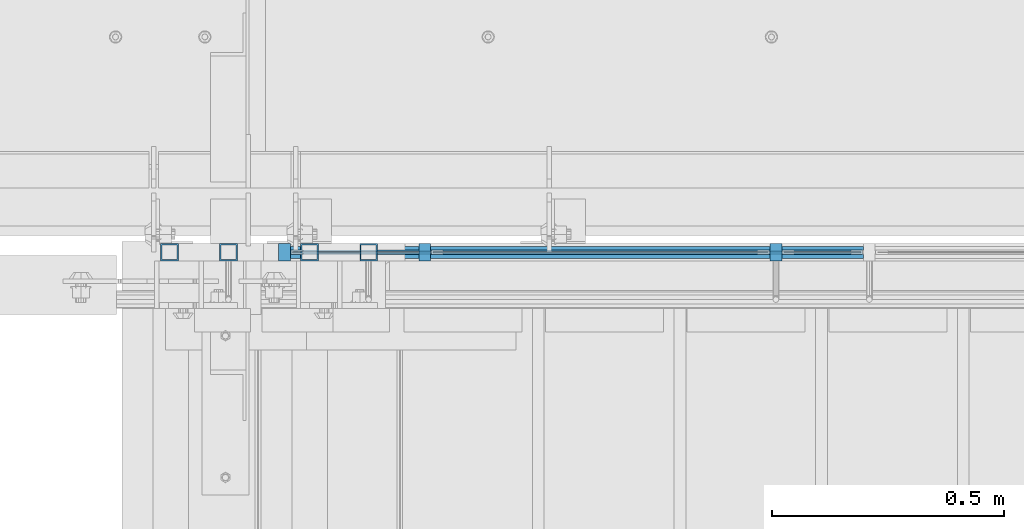
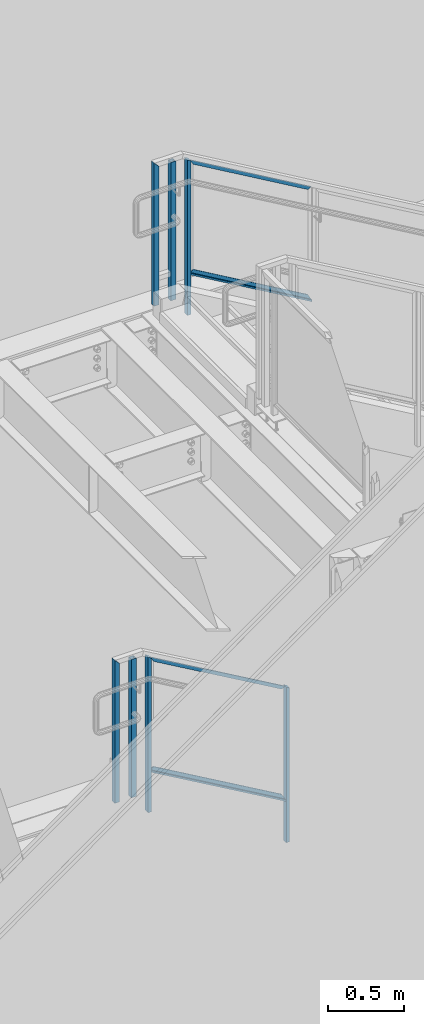
# One storey, part 792 of 1179: 9 members, 4 beams, 2 elements without a shape of their own.
"""IFC2X3 building model written with IfcOpenShell, lengths in millimetres."""

from ifc_helpers import new_model, si_unit, frame, origin_with_axes, place, context, subcontext, project, spatial, faceted_brep, material, type_object, element, aggregate, save


model = new_model("IFC2X3")

# Units and contexts
model_context = context("Model", 3, precision=1e-05, world=origin_with_axes())
body_context = subcontext(model_context, "Body", "Model", "MODEL_VIEW")
ifc_project = project(units=[si_unit("LENGTHUNIT", "METRE", prefix="MILLI"), si_unit("AREAUNIT", "SQUARE_METRE"), si_unit("VOLUMEUNIT", "CUBIC_METRE"), si_unit("MASSUNIT", "GRAM", prefix="KILO"), si_unit("TIMEUNIT", "SECOND"), si_unit("PLANEANGLEUNIT", "RADIAN"), si_unit("SOLIDANGLEUNIT", "STERADIAN"), si_unit("THERMODYNAMICTEMPERATUREUNIT", "DEGREE_CELSIUS"), si_unit("LUMINOUSINTENSITYUNIT", "LUMEN")], contexts=[model_context])

# Site, building, storey
site_placement = place(None, origin_with_axes())
site = spatial("IfcSite", under=ifc_project, at=site_placement, CompositionType="ELEMENT")
building_placement = place(site_placement, origin_with_axes())
building = spatial("IfcBuilding", under=site, at=building_placement, Name="Undefined", CompositionType="ELEMENT")
storey_placement = place(building_placement, origin_with_axes())
storey = spatial("IfcBuildingStorey", under=building, at=storey_placement, Name="Undefined", CompositionType="ELEMENT", Elevation=0.0)

# Assembly, member
assembly_1_placement = place(storey_placement, origin_with_axes())
assembly_1 = element("IfcElementAssembly", 1, at=assembly_1_placement, inside=storey, Name="GUARDRAIL", AssemblyPlace="NOTDEFINED", PredefinedType="RIGID_FRAME")
ifc_material_1 = material(Name="STEEL/A36")
member_type_1 = type_object("IfcMemberType", PredefinedType="NOTDEFINED")
member_1_placement = place(assembly_1_placement, frame((19853.2749999269, 41065.449999238, 7913.42903983498), z_axis=(0.0, -1.0, 0.0), x_axis=(0.0, 0.0, 1.0)))
member_1 = element("IfcMember", 2, at=member_1_placement, type_object=member_type_1, material=ifc_material_1, Name="POST", context=body_context, shape_type="Brep", body=[
    faceted_brep([(0.0, 12.7000000000007, -19.0500000000029), (0.0, 12.7000000000007, 19.0500000000029), (1257.9937907086, 12.7000000000007, 19.0500000000029), (1257.9937907086, 12.7000000000007, -19.0500000000029), (0.0, -12.7000000000007, 19.0500000000029), (1243.17712405909, -12.7000000000007, 19.0500000000029), (0.0, -12.7000000000007, -19.0500000000029), (1243.17712405909, -12.7000000000007, -19.0500000000029)], [[[0, 1, 2, 3]], [[1, 4, 5, 2]], [[4, 6, 7, 5]], [[6, 0, 3, 7]], [[5, 7, 3, 2]], [[6, 4, 1, 0]]]),
])

# Assembly, members
assembly_2_placement = place(storey_placement, origin_with_axes())
assembly_2 = element("IfcElementAssembly", 3, at=assembly_2_placement, inside=storey, Name="GUARDRAIL", AssemblyPlace="NOTDEFINED", PredefinedType="RIGID_FRAME")
member_2_placement = place(assembly_2_placement, frame((20608.9249611471, 41065.4499993604, 3388.43033674532), z_axis=(0.0, -1.0, 0.0), x_axis=(0.0, 0.0, 1.0)))
member_2 = element("IfcMember", 4, at=member_2_placement, type_object=member_type_1, material=ifc_material_1, Name="POST", context=body_context, shape_type="Brep", body=[
    faceted_brep([(0.0, 12.7000000000007, -19.0500000000029), (0.0, 12.7000000000007, 19.0500000000029), (1257.59245944594, 12.7000000000007, 19.0500000000029), (1257.59245944594, 12.7000000000007, -19.0500000000029), (0.0, -12.7000000000007, 19.0500000000029), (1242.88603583053, -12.7000000000007, 19.0500000000029), (0.0, -12.7000000000007, -19.0500000000029), (1242.88603583053, -12.7000000000007, -19.0500000000029)], [[[0, 1, 2, 3]], [[1, 4, 5, 2]], [[4, 6, 7, 5]], [[6, 0, 3, 7]], [[5, 7, 3, 2]], [[6, 4, 1, 0]]]),
])
member_3_placement = place(assembly_2_placement, frame((19551.6499976895, 41065.4499993638, 4000.58519857922), z_axis=(0.0, -1.0, 0.0), x_axis=(0.0, 0.0, 1.0)))
member_3 = element("IfcMember", 5, at=member_3_placement, type_object=member_type_1, material=ifc_material_1, Name="POST", context=body_context, shape_type="Brep", body=[
    faceted_brep([(1242.88603583053, -12.7000000000007, 19.0500000000029), (1242.88603583053, -12.7000000000007, -19.0500000000029), (1257.59245944594, 12.7000000000007, -19.0500000000029), (1257.59245944594, 12.7000000000007, 19.0500000000029), (0.0, -12.7000000000007, -19.0500000000029), (0.0, -12.7000000000007, 19.0500000000029), (0.0, 12.7000000000007, 19.0500000000029), (0.0, 12.7000000000007, -19.0500000000029)], [[[0, 1, 2, 3]], [[4, 5, 6, 7]], [[7, 6, 3, 2]], [[4, 7, 2, 1]], [[5, 4, 1, 0]], [[6, 5, 0, 3]]]),
])

# Beam
ifc_material_2 = material(Name="STEEL/BUY-OUT")
beam_type = type_object("IfcBeamType", PredefinedType="NOTDEFINED")
beam_1_placement = place(assembly_1_placement, frame((20294.9861896626, 41062.2751647691, 8025.17294760653), z_axis=(0.863778851027978, 0.0, -0.503871111016285), x_axis=(-0.503871111016286, 0.0, -0.863778851027978)))
beam_1 = element("IfcBeam", 6, at=beam_1_placement, type_object=beam_type, material=ifc_material_2, Name="U-EDGE", context=body_context, shape_type="Brep", body=[
    faceted_brep([(3.02679836750031e-09, 1.58750000000146, -465.424288071716), (3.02316038869321e-09, -1.58750000000146, -465.424288071717), (-3.58704710379243e-09, -1.58750000000146, 550.296660657488), (-3.58704710379243e-09, 1.58750000000146, 550.296660657488), (22.2250000928143, 1.58750000000146, -478.189679507572), (22.2250000632448, 1.58750000000146, 588.991208057043), (22.2250000826898, 4.76250001285371, -478.189679501758), (22.2250000757122, 4.76249998416461, 588.991208078747), (1.59241608344018e-07, 4.76250000984146, -465.424288161439), (1.58372131409124e-07, 4.76249998836283, 550.296660939461), (1.59241608344018e-07, 7.93750000983709, -465.424288161439), (1.58372131409124e-07, 7.93749998836574, 550.296660939461), (25.4000000827036, 7.93750001290027, -480.013306842378), (25.4000000343149, 7.9375, 594.519), (25.4000000928609, -1.58750000000146, -480.013306848216), (25.4000000343149, -1.58750000000146, 594.519)], [[[0, 1, 2, 3]], [[4, 0, 3, 5]], [[6, 4, 5, 7]], [[8, 6, 7, 9]], [[10, 8, 9, 11]], [[12, 10, 11, 13]], [[14, 12, 13, 15]], [[11, 9, 7, 5, 3, 2, 15, 13]], [[1, 14, 15, 2]], [[0, 4, 6, 8, 10, 12, 14, 1]]]),
])

beam_2_placement = place(assembly_1_placement, frame((20269.3895413051, 41062.2751647691, 8890.03748633002), z_axis=(0.863778851027978, 0.0, -0.503871111016285), x_axis=(0.503871025088838, 0.0, 0.863778901152328)))
beam_2 = element("IfcBeam", 7, at=beam_2_placement, type_object=beam_type, material=ifc_material_2, Name="U-EDGE", context=body_context, shape_type="Brep", body=[
    faceted_brep([(-1.33470166474581e-07, -4.76249999994616, -435.790965618296), (-1.33470166474581e-07, -7.93749999994907, -435.790965618296), (-1.34041329147294e-07, -7.93750000006548, 579.929993147438), (-1.34041329147294e-07, -4.76250000006257, 579.929993147438), (22.224999933358, -4.76249999989523, -474.486507128395), (22.2249999328378, -4.76250000012806, 592.695373883196), (22.2249999333071, -1.58750000000146, -474.486507128307), (22.2249999328997, -1.58750000000146, 592.695373883229), (2.25554686039686e-10, -1.58750000000146, -435.790965851076), (0.0, -1.58750000000146, 579.92999369853), (2.25554686039686e-10, 1.58750000000146, -435.790965851076), (0.0, 1.58750000000146, 579.92999369853), (25.39999993331, 1.58750000000146, -480.014441613133), (25.3999999489688, 1.58750000000146, 594.519), (25.399999933361, -7.93749999989086, -480.014441613221), (25.3999999489688, -7.9375, 594.519)], [[[0, 1, 2, 3]], [[4, 0, 3, 5]], [[6, 4, 5, 7]], [[8, 6, 7, 9]], [[10, 8, 9, 11]], [[12, 10, 11, 13]], [[14, 12, 13, 15]], [[11, 9, 7, 5, 3, 2, 15, 13]], [[1, 14, 15, 2]], [[0, 4, 6, 8, 10, 12, 14, 1]]]),
])

beam_3_placement = place(assembly_2_placement, frame((20092.8623203506, 41062.2751647691, 4055.74095164783), z_axis=(0.86540914081268, 0.0, -0.501065882891521), x_axis=(-0.501065882891527, 0.0, -0.865409140812677)))
beam_3 = element("IfcBeam", 8, at=beam_3_placement, type_object=beam_type, material=ifc_material_2, Name="U-EDGE", context=body_context, shape_type="Brep", body=[
    faceted_brep([(-2.17914930544794e-09, 1.58750000000146, -579.8750616161), (-2.17914930544794e-09, -1.58750000000146, -579.8750616161), (2.06819095183164e-09, -1.58750000000146, 550.462303003866), (2.06819095183164e-09, 1.58750000000146, 550.462303003866), (22.2250000220702, 1.58750000000146, -592.688577145202), (22.225000051898, 1.58750000000146, 589.01191290709), (22.225000034794, 4.76249998386629, -592.688577152541), (22.2250000392505, 4.7625000160333, 589.011912885151), (7.50696926843375e-08, 4.76249998754065, -579.875061660634), (7.28450686438009e-08, 4.7625000118278, 550.462303126626), (7.50696926843375e-08, 7.93749998753628, -579.875061660634), (7.28450686438009e-08, 7.93750001182343, 550.462303126626), (25.4000000347896, 7.93749998381099, -594.518999999977), (25.4000000343149, 7.9375, 594.519), (25.4000000220258, -1.58750000000146, -594.518999999807), (25.4000000343149, -1.58750000000146, 594.519)], [[[0, 1, 2, 3]], [[4, 0, 3, 5]], [[6, 4, 5, 7]], [[8, 6, 7, 9]], [[10, 8, 9, 11]], [[12, 10, 11, 13]], [[14, 12, 13, 15]], [[11, 9, 7, 5, 3, 2, 15, 13]], [[1, 14, 15, 2]], [[0, 4, 6, 8, 10, 12, 14, 1]]]),
])

beam_4_placement = place(assembly_2_placement, frame((20067.408210734, 41062.2751647691, 4921.4162257045), z_axis=(0.86540914081268, 0.0, -0.501065882891521), x_axis=(0.501065882891522, 0.0, 0.865409140812679)))
beam_4 = element("IfcBeam", 9, at=beam_4_placement, type_object=beam_type, material=ifc_material_2, Name="U-EDGE", context=body_context, shape_type="Brep", body=[
    faceted_brep([(-5.08043740410358e-09, -4.76250001176231, -550.462297073285), (-5.08043740410358e-09, -7.93750001176522, -550.462297073285), (2.06819095183164e-09, -7.93749998760177, 579.875144306196), (2.06819095183164e-09, -4.76249998760613, 579.875144306196), (22.2249999989635, -4.76250001590233, -589.011912123857), (22.2249999997566, -4.76249998399726, 592.68851804268), (22.2250000115582, -1.58750000000146, -589.011912145696), (22.2249999870892, -1.58750000000146, 592.68851803538), (-3.47426976077259e-10, -1.58750000000146, -550.462297081494), (3.69254848919809e-10, -1.58750000000146, 579.875144305217), (-3.47426976077259e-10, 1.58750000000146, -550.462297081494), (3.69254848919809e-10, 1.58750000000146, 579.875144305217), (25.4000001784334, 1.58750000000146, -594.51900000087), (25.3999999489688, 1.58750000000146, 594.519), (25.4000002532193, -7.93749990531796, -594.51900000187), (25.3999999489688, -7.9375, 594.519)], [[[0, 1, 2, 3]], [[4, 0, 3, 5]], [[6, 4, 5, 7]], [[8, 6, 7, 9]], [[10, 8, 9, 11]], [[12, 10, 11, 13]], [[14, 12, 13, 15]], [[11, 9, 7, 5, 3, 2, 15, 13]], [[1, 14, 15, 2]], [[0, 4, 6, 8, 10, 12, 14, 1]]]),
])

# Member
ifc_material_3 = material()
member_type_2 = type_object("IfcMemberType", Name="HSS1-1/2X1-1/2X1/8", PredefinedType="NOTDEFINED")
member_4_placement = place(assembly_1_placement, frame((19605.6249991619, 41065.449999238, 8070.85000060476), z_axis=(-1.0, 0.0, 0.0), x_axis=(0.0, 0.0, 1.0)))
member_4 = element("IfcMember", 10, at=member_4_placement, type_object=member_type_2, material=ifc_material_3, Name="POST", ObjectType="HSS1-1/2X1-1/2X1/8", context=body_context, shape_type="Brep", body=[
    faceted_brep([(6.35000000000014, 15.874999282998, -15.8749992830017), (6.35000000000014, -15.874999282998, -15.8749992830017), (1127.12500011961, -15.874999282998, -15.8749992830017), (1127.12500011961, 15.874999282998, -15.8749992830017), (6.35000000000014, -15.874999282998, 15.8749992830017), (1158.87499868561, -15.874999282998, 15.8749992830017), (6.35000000000014, 15.874999282998, 15.8749992830017), (1158.87499868561, 15.874999282998, 15.8749992830017), (6.35000000000014, 19.0499992350015, -19.0499992350015), (6.35000000000014, 19.0499992350015, 19.0499992350015), (1162.04999863761, 19.0499992350015, 19.0499992350015), (1123.95000016761, 19.0499992350015, -19.0499992350015), (6.35000000000014, -19.0499992350015, 19.0499992350015), (1162.04999863761, -19.0499992350015, 19.0499992350015), (6.35000000000014, -19.0499992350015, -19.0499992350015), (1123.95000016761, -19.0499992350015, -19.0499992350015)], [[[0, 1, 2, 3]], [[1, 4, 5, 2]], [[4, 6, 7, 5]], [[6, 0, 3, 7]], [[8, 9, 10, 11]], [[9, 12, 13, 10]], [[12, 14, 15, 13]], [[14, 8, 11, 15]], [[13, 15, 11, 10], [5, 7, 3, 2]], [[14, 12, 9, 8], [6, 4, 1, 0]]]),
])

member_5_placement = place(assembly_1_placement, frame((19732.6249999269, 41065.449999238, 8070.85000000882), z_axis=(-1.0, 0.0, 0.0), x_axis=(0.0, 0.0, 1.0)))
member_5 = element("IfcMember", 11, at=member_5_placement, type_object=member_type_2, material=ifc_material_3, Name="POST", ObjectType="HSS1-1/2X1-1/2X1/8", context=body_context, shape_type="Brep", body=[
    faceted_brep([(6.35000000000014, -19.0499992350015, -19.0499992350015), (6.35000000000014, 19.0499992350015, -19.0499992350015), (1123.95000016761, 19.0499992350015, -19.0499992350015), (1123.95000016761, -19.0499992350015, -19.0499992350015), (6.35000000000014, -19.0499992350015, 19.0499992350015), (1123.95000141407, -19.0499992350015, 19.0499992350015), (6.35000000000014, 19.0499992350015, 19.0499992350015), (1123.95000141407, 19.0499992350015, 19.0499992350015), (6.35000000000014, 15.874999282998, 15.8749992830017), (6.35000000000014, -15.874999282998, 15.8749992830017), (6.35000000000014, -15.874999282998, -15.8749992830017), (6.35000000000014, 15.874999282998, -15.8749992830017), (1123.95000140455, -15.874999282998, 15.8749992830017), (1123.9500013093, -15.874999282998, -15.8749992830017), (1123.9500013093, 15.874999282998, -15.8749992830017), (1123.95000140455, 15.874999282998, 15.8749992830017)], [[[0, 1, 2, 3]], [[4, 0, 3, 5]], [[6, 4, 5, 7]], [[1, 6, 7, 2]], [[0, 4, 6, 1], [8, 9, 10, 11]], [[10, 9, 12, 13]], [[11, 10, 13, 14]], [[8, 11, 14, 15]], [[9, 8, 15, 12]], [[2, 7, 5, 3], [14, 13, 12, 15]]]),
])

member_6_placement = place(assembly_2_placement, frame((19430.9999984545, 41065.4499993638, 4159.24999940411), z_axis=(-1.0, 0.0, 0.0), x_axis=(0.0, 0.0, 1.0)))
member_6 = element("IfcMember", 12, at=member_6_placement, type_object=member_type_2, material=ifc_material_3, Name="POST", ObjectType="HSS1-1/2X1-1/2X1/8", context=body_context, shape_type="Brep", body=[
    faceted_brep([(1123.95000016761, 19.0499992350015, -19.0499992350015), (1123.95000141407, 19.0499992350015, 19.0499992350015), (1123.95000141407, -19.0499992350015, 19.0499992350015), (1123.95000016761, -19.0499992350015, -19.0499992350015), (1123.9500013093, 15.874999282998, -15.8749992830017), (1123.9500013093, -15.874999282998, -15.8749992830017), (1123.95000140455, -15.874999282998, 15.8749992830017), (1123.95000140455, 15.874999282998, 15.8749992830017), (6.35000000000014, 19.0499992350015, 19.0499992350015), (6.35000000000014, -19.0499992350015, 19.0499992350015), (6.35000000000014, -19.0499992350015, -19.0499992350015), (6.35000000000014, 19.0499992350015, -19.0499992350015), (6.35000000000014, 15.874999282998, 15.8749992830017), (6.35000000000014, -15.874999282998, 15.8749992830017), (6.35000000000014, -15.874999282998, -15.8749992830017), (6.35000000000014, 15.874999282998, -15.8749992830017)], [[[0, 1, 2, 3], [4, 5, 6, 7]], [[8, 9, 2, 1]], [[10, 11, 0, 3]], [[9, 10, 3, 2]], [[11, 8, 1, 0]], [[10, 9, 8, 11], [12, 13, 14, 15]], [[14, 13, 6, 5]], [[15, 14, 5, 4]], [[12, 15, 4, 7]], [[13, 12, 7, 6]]]),
])

member_7_placement = place(assembly_2_placement, frame((19303.9999999845, 41065.4499993638, 4159.24999878531), z_axis=(-1.0, 0.0, 0.0), x_axis=(0.0, 0.0, 1.0)))
member_7 = element("IfcMember", 13, at=member_7_placement, type_object=member_type_2, material=ifc_material_3, Name="POST", ObjectType="HSS1-1/2X1-1/2X1/8", context=body_context, shape_type="Brep", body=[
    faceted_brep([(6.35000000000014, 15.874999282998, -15.8749992830017), (6.35000000000014, -15.874999282998, -15.8749992830017), (1127.12500011961, -15.874999282998, -15.8749992830017), (1127.12500011961, 15.874999282998, -15.8749992830017), (6.35000000000014, -15.874999282998, 15.8749992830017), (1158.87499868561, -15.874999282998, 15.8749992830017), (6.35000000000014, 15.874999282998, 15.8749992830017), (1158.87499868561, 15.874999282998, 15.8749992830017), (6.35000000000014, 19.0499992350015, -19.0499992350015), (6.35000000000014, 19.0499992350015, 19.0499992350015), (1162.04999863761, 19.0499992350015, 19.0499992350015), (1123.95000016761, 19.0499992350015, -19.0499992350015), (6.35000000000014, -19.0499992350015, 19.0499992350015), (1162.04999863761, -19.0499992350015, 19.0499992350015), (6.35000000000014, -19.0499992350015, -19.0499992350015), (1123.95000016761, -19.0499992350015, -19.0499992350015)], [[[0, 1, 2, 3]], [[1, 4, 5, 2]], [[4, 6, 7, 5]], [[6, 0, 3, 7]], [[8, 9, 10, 11]], [[9, 12, 13, 10]], [[12, 14, 15, 13]], [[14, 8, 11, 15]], [[13, 15, 11, 10], [5, 7, 3, 2]], [[14, 12, 9, 8], [6, 4, 1, 0]]]),
])

member_type_3 = type_object("IfcMemberType", PredefinedType="NOTDEFINED")
member_8_placement = place(assembly_1_placement, frame((19853.2749999269, 41065.449999238, 8244.24286240685), z_axis=(0.0, -1.0, 0.0), x_axis=(0.863778851027978, 0.0, -0.503871111016285)))
member_8 = element("IfcMember", 14, at=member_8_placement, type_object=member_type_3, material=ifc_material_1, Name="BOTTOM_RAIL", context=body_context, shape_type="Brep", body=[
    faceted_brep([(10.9986698874163, 6.34999999999854, -12.6999999999971), (10.9986698874163, 6.34999999999854, 12.6999999999971), (1089.20668431148, 6.35000000024229, 12.6999999999971), (1089.20668431148, 6.35000000024229, -12.6999999999971), (18.4070032121654, -6.34999999999127, 12.6999999999971), (1096.61501763624, -6.34999999974752, 12.6999999999971), (18.4070032121654, -6.34999999999127, -12.6999999999971), (1096.61501763624, -6.34999999974752, -12.6999999999971)], [[[0, 1, 2, 3]], [[1, 4, 5, 2]], [[4, 6, 7, 5]], [[6, 0, 3, 7]], [[5, 7, 3, 2]], [[6, 4, 1, 0]]]),
])

aggregate(assembly_1, [beam_1, beam_2, member_8, member_4, member_1, member_5])

member_9_placement = place(assembly_2_placement, frame((19551.6499976848, 41065.4499993604, 4330.77584080213), z_axis=(0.0, -1.0, 0.0), x_axis=(0.86540914081268, 0.0, -0.501065882891521)))
member_9 = element("IfcMember", 15, at=member_9_placement, type_object=member_type_3, material=ifc_material_1, Name="BOTTOM_RAIL", context=body_context, shape_type="Brep", body=[
    faceted_brep([(10.998533752896, 6.34999999999854, -12.6999999999971), (10.998533752896, 6.34999999999854, 12.6999999999971), (1203.35358848741, 6.35000000053878, 12.6999999999971), (1203.35358848741, 6.35000000053878, -12.6999999999971), (18.3517455606161, -6.34999999998945, 12.6999999999971), (1210.70680029513, -6.34999999944921, 12.6999999999971), (18.3517455606161, -6.34999999998945, -12.6999999999971), (1210.70680029513, -6.34999999944921, -12.6999999999971)], [[[0, 1, 2, 3]], [[1, 4, 5, 2]], [[4, 6, 7, 5]], [[6, 0, 3, 7]], [[5, 7, 3, 2]], [[6, 4, 1, 0]]]),
])

aggregate(assembly_2, [beam_3, beam_4, member_9, member_2, member_6, member_7, member_3])

save(model, "model.ifc")
